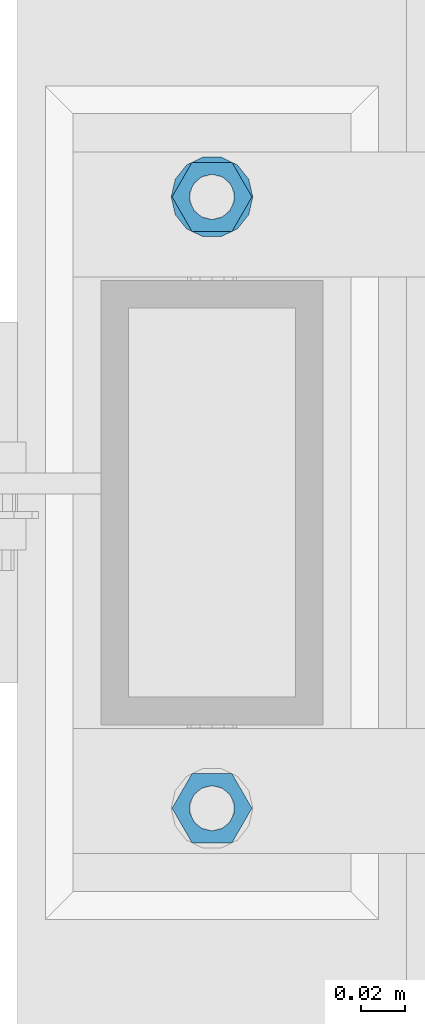
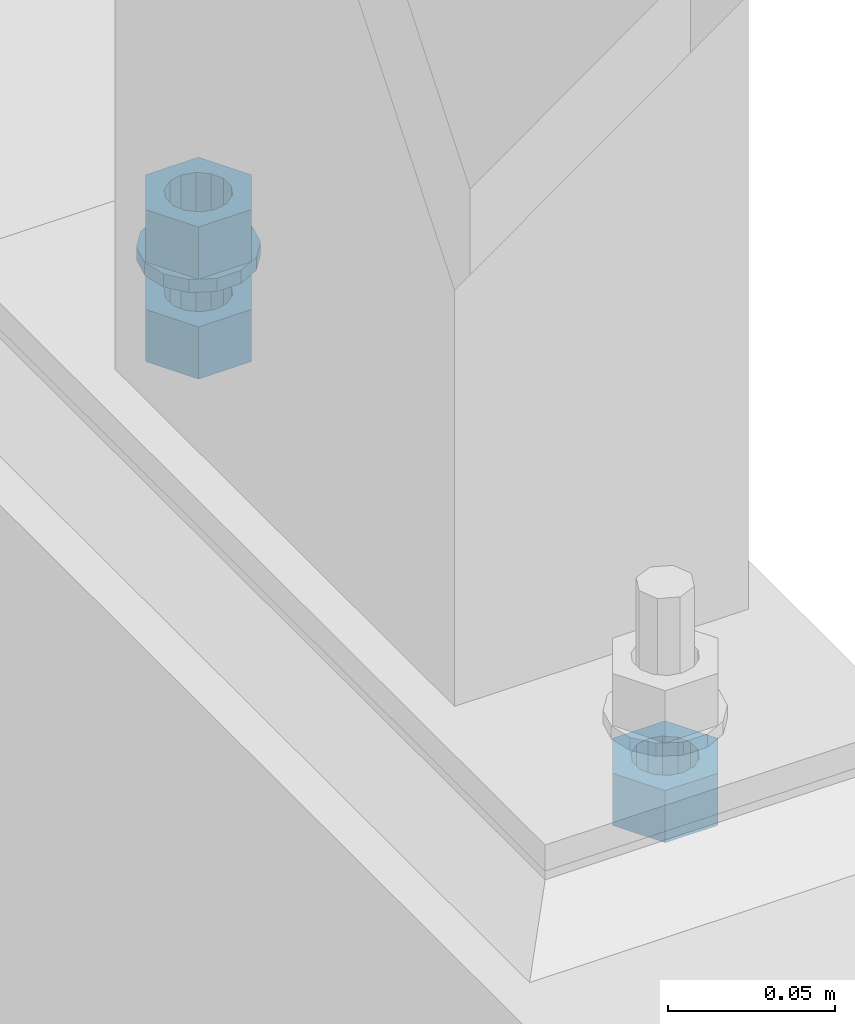
# One storey, part 581 of 975: 4 beams.
"""IFC2X3 building model written with IfcOpenShell, lengths in millimetres."""

from ifc_helpers import new_model, si_unit, frame, origin_with_axes, place, context, subcontext, project, spatial, faceted_brep, material, type_object, element, save


model = new_model("IFC2X3")

# Units and contexts
model_context = context("Model", 3, precision=1e-05, world=origin_with_axes())
body_context = subcontext(model_context, "Body", "Model", "MODEL_VIEW")
ifc_project = project(units=[si_unit("LENGTHUNIT", "METRE", prefix="MILLI"), si_unit("AREAUNIT", "SQUARE_METRE"), si_unit("VOLUMEUNIT", "CUBIC_METRE"), si_unit("MASSUNIT", "GRAM", prefix="KILO"), si_unit("TIMEUNIT", "SECOND"), si_unit("PLANEANGLEUNIT", "RADIAN"), si_unit("SOLIDANGLEUNIT", "STERADIAN"), si_unit("THERMODYNAMICTEMPERATUREUNIT", "DEGREE_CELSIUS"), si_unit("LUMINOUSINTENSITYUNIT", "LUMEN")], contexts=[model_context])

# Site, building, storey
site_placement = place(None, origin_with_axes())
site = spatial("IfcSite", under=ifc_project, at=site_placement, CompositionType="ELEMENT")
building_placement = place(site_placement, origin_with_axes())
building = spatial("IfcBuilding", under=site, at=building_placement, Name="Undefined", CompositionType="ELEMENT")
storey_placement = place(building_placement, origin_with_axes())
storey = spatial("IfcBuildingStorey", under=building, at=storey_placement, Name="Undefined", CompositionType="ELEMENT", Elevation=0.0)

# Beams
ifc_material = material(Name="STEEL/A36")
beam_type_1 = type_object("IfcBeamType", Name="3/4_WASHER", PredefinedType="NOTDEFINED")
beam_1_placement = place(storey_placement, frame((26492.2, 3830.63747558594, 42.8625000000034), z_axis=(0.0, 1.0, 0.0), x_axis=(0.0, 0.0, -1.0)))
element("IfcBeam", 1, at=beam_1_placement, inside=storey, type_object=beam_type_1, material=ifc_material, Name="WASHER", ObjectType="3/4_WASHER", context=body_context, shape_type="Brep", body=[
    faceted_brep([(0.0, -18.6499996185303, 0.0), (0.0, -16.8030690426876, -8.09193156902904), (4.76250000000073, -16.8030690426876, -8.09193156902904), (4.76250000000073, -18.6499996185303, 0.0), (0.0, -11.6280845668225, -14.5811568497838), (4.76250000000073, -11.6280845668225, -14.5811568497838), (0.0, -4.15001533340001, -18.1824051902857), (4.76250000000073, -4.15001533340001, -18.1824051902857), (0.0, 4.15001533340001, -18.1824051902857), (4.76250000000073, 4.15001533340001, -18.1824051902857), (0.0, 11.6280845668234, -14.5811568497838), (4.76250000000073, 11.6280845668234, -14.5811568497838), (0.0, 16.8030690426876, -8.09193156902904), (4.76250000000073, 16.8030690426876, -8.09193156902904), (0.0, 18.6499996185303, 0.0), (4.76250000000073, 18.6499996185303, 0.0), (0.0, 16.8030690426876, 8.09193156902904), (4.76250000000073, 16.8030690426876, 8.09193156902904), (0.0, 11.6280845668225, 14.5811568497838), (4.76250000000073, 11.6280845668225, 14.5811568497838), (0.0, 4.15001533340001, 18.1824051902857), (4.76250000000073, 4.15001533340001, 18.1824051902857), (0.0, -4.15001533340001, 18.1824051902857), (4.76250000000073, -4.15001533340001, 18.1824051902857), (0.0, -11.6280845668234, 14.5811568497838), (4.76250000000073, -11.6280845668234, 14.5811568497838), (0.0, -16.8030690426876, 8.09193156902904), (4.76250000000073, -16.8030690426876, 8.09193156902904), (0.0, 0.0, 10.3199996948242), (0.0, 4.47768005528269, 9.29799844179911), (4.76250000000073, 4.47768005528269, 9.29799844179911), (4.76250000000073, 0.0, 10.3199996948242), (0.0, 8.06850066047446, 6.43441456490817), (4.76250000000073, 8.06850066047446, 6.43441456490817), (0.0, 10.0612557561917, 2.29641597052117), (4.76250000000073, 10.0612557561917, 2.29641597052117), (0.0, 10.0612557561917, -2.29641597052117), (4.76250000000073, 10.0612557561917, -2.29641597052117), (0.0, 8.06850066047446, -6.43441456490814), (4.76250000000073, 8.06850066047446, -6.43441456490814), (0.0, 4.47768005528269, -9.29799844179908), (4.76250000000073, 4.47768005528269, -9.29799844179908), (0.0, 0.0, -10.3199996948242), (4.76250000000073, 0.0, -10.3199996948242), (0.0, -4.47768005528269, -9.29799844179911), (4.76250000000073, -4.47768005528269, -9.29799844179911), (0.0, -8.06850066047446, -6.43441456490817), (4.76250000000073, -8.06850066047446, -6.43441456490817), (0.0, -10.0612557561917, -2.29641597052117), (4.76250000000073, -10.0612557561917, -2.29641597052117), (0.0, -10.0612557561917, 2.29641597052117), (4.76250000000073, -10.0612557561917, 2.29641597052117), (0.0, -8.06850066047446, 6.43441456490814), (4.76250000000073, -8.06850066047446, 6.43441456490814), (0.0, -4.47768005528269, 9.29799844179908), (4.76250000000073, -4.47768005528269, 9.29799844179908)], [[[0, 1, 2, 3]], [[1, 4, 5, 2]], [[4, 6, 7, 5]], [[6, 8, 9, 7]], [[8, 10, 11, 9]], [[10, 12, 13, 11]], [[12, 14, 15, 13]], [[14, 16, 17, 15]], [[16, 18, 19, 17]], [[18, 20, 21, 19]], [[20, 22, 23, 21]], [[22, 24, 25, 23]], [[24, 26, 27, 25]], [[26, 0, 3, 27]], [[28, 29, 30, 31]], [[29, 32, 33, 30]], [[32, 34, 35, 33]], [[34, 36, 37, 35]], [[36, 38, 39, 37]], [[38, 40, 41, 39]], [[40, 42, 43, 41]], [[42, 44, 45, 43]], [[44, 46, 47, 45]], [[46, 48, 49, 47]], [[48, 50, 51, 49]], [[50, 52, 53, 51]], [[52, 54, 55, 53]], [[54, 28, 31, 55]], [[5, 7, 9, 11, 13, 15, 17, 19, 21, 23, 25, 27, 3, 2], [33, 35, 37, 39, 41, 43, 45, 47, 49, 51, 53, 55, 31, 30]], [[26, 24, 22, 20, 18, 16, 14, 12, 10, 8, 6, 4, 1, 0], [54, 52, 50, 48, 46, 44, 42, 40, 38, 36, 34, 32, 29, 28]]]),
])
beam_type_2 = type_object("IfcBeamType", Name="3/4_HEAVY_HEX_NUT", PredefinedType="NOTDEFINED")
beam_2_placement = place(storey_placement, frame((26492.2, 3551.23747558594, 25.4000000000037), z_axis=(0.0, 1.0, 0.0), x_axis=(0.0, 0.0, -1.0)))
element("IfcBeam", 2, at=beam_2_placement, inside=storey, type_object=beam_type_2, material=ifc_material, Name="NUT", ObjectType="3/4_HEAVY_HEX_NUT", context=body_context, shape_type="Brep", body=[
    faceted_brep([(0.0, -18.2600002288818, 0.0), (0.0, -9.13000011444092, -15.8100004196167), (19.0499999999993, -9.13000011444092, -15.8100004196167), (19.0499999999993, -18.2600002288818, 0.0), (0.0, 9.13000011444092, -15.8100004196167), (19.0499999999993, 9.13000011444092, -15.8100004196167), (0.0, 18.2600002288818, 0.0), (19.0499999999993, 18.2600002288818, 0.0), (0.0, 9.13000011444092, 15.8100004196167), (19.0499999999993, 9.13000011444092, 15.8100004196167), (0.0, -9.13000011444092, 15.8100004196167), (19.0499999999993, -9.13000011444092, 15.8100004196167), (0.0, 0.0, 10.3199996948242), (0.0, 4.47768005528269, 9.29799844179911), (19.0499999999993, 4.47768005528269, 9.29799844179911), (19.0499999999993, 0.0, 10.3199996948242), (0.0, 8.06850066047446, 6.43441456490817), (19.0499999999993, 8.06850066047446, 6.43441456490817), (0.0, 10.0612557561917, 2.29641597052117), (19.0499999999993, 10.0612557561917, 2.29641597052117), (0.0, 10.0612557561917, -2.29641597052117), (19.0499999999993, 10.0612557561917, -2.29641597052117), (0.0, 8.06850066047446, -6.43441456490814), (19.0499999999993, 8.06850066047446, -6.43441456490814), (0.0, 4.47768005528269, -9.29799844179908), (19.0499999999993, 4.47768005528269, -9.29799844179908), (0.0, 0.0, -10.3199996948242), (19.0499999999993, 0.0, -10.3199996948242), (0.0, -4.47768005528269, -9.29799844179911), (19.0499999999993, -4.47768005528269, -9.29799844179911), (0.0, -8.06850066047446, -6.43441456490817), (19.0499999999993, -8.06850066047446, -6.43441456490817), (0.0, -10.0612557561917, -2.29641597052117), (19.0499999999993, -10.0612557561917, -2.29641597052117), (0.0, -10.0612557561917, 2.29641597052117), (19.0499999999993, -10.0612557561917, 2.29641597052117), (0.0, -8.06850066047446, 6.43441456490814), (19.0499999999993, -8.06850066047446, 6.43441456490814), (0.0, -4.47768005528269, 9.29799844179908), (19.0499999999993, -4.47768005528269, 9.29799844179908)], [[[0, 1, 2, 3]], [[1, 4, 5, 2]], [[4, 6, 7, 5]], [[6, 8, 9, 7]], [[8, 10, 11, 9]], [[10, 0, 3, 11]], [[12, 13, 14, 15]], [[13, 16, 17, 14]], [[16, 18, 19, 17]], [[18, 20, 21, 19]], [[20, 22, 23, 21]], [[22, 24, 25, 23]], [[24, 26, 27, 25]], [[26, 28, 29, 27]], [[28, 30, 31, 29]], [[30, 32, 33, 31]], [[32, 34, 35, 33]], [[34, 36, 37, 35]], [[36, 38, 39, 37]], [[38, 12, 15, 39]], [[5, 7, 9, 11, 3, 2], [17, 19, 21, 23, 25, 27, 29, 31, 33, 35, 37, 39, 15, 14]], [[10, 8, 6, 4, 1, 0], [38, 36, 34, 32, 30, 28, 26, 24, 22, 20, 18, 16, 13, 12]]]),
])
beam_3_placement = place(storey_placement, frame((26492.2, 3830.63747558594, 61.9125000000026), z_axis=(0.0, 1.0, 0.0), x_axis=(0.0, 0.0, -1.0)))
element("IfcBeam", 3, at=beam_3_placement, inside=storey, type_object=beam_type_2, material=ifc_material, Name="NUT", ObjectType="3/4_HEAVY_HEX_NUT", context=body_context, shape_type="Brep", body=[
    faceted_brep([(0.0, -18.2600002288818, 0.0), (0.0, -9.13000011444092, -15.8100004196167), (19.0499999999993, -9.13000011444092, -15.8100004196167), (19.0499999999993, -18.2600002288818, 0.0), (0.0, 9.13000011444092, -15.8100004196167), (19.0499999999993, 9.13000011444092, -15.8100004196167), (0.0, 18.2600002288818, 0.0), (19.0499999999993, 18.2600002288818, 0.0), (0.0, 9.13000011444092, 15.8100004196167), (19.0499999999993, 9.13000011444092, 15.8100004196167), (0.0, -9.13000011444092, 15.8100004196167), (19.0499999999993, -9.13000011444092, 15.8100004196167), (0.0, 0.0, 10.3199996948242), (0.0, 4.47768005528269, 9.29799844179911), (19.0499999999993, 4.47768005528269, 9.29799844179911), (19.0499999999993, 0.0, 10.3199996948242), (0.0, 8.06850066047446, 6.43441456490817), (19.0499999999993, 8.06850066047446, 6.43441456490817), (0.0, 10.0612557561917, 2.29641597052117), (19.0499999999993, 10.0612557561917, 2.29641597052117), (0.0, 10.0612557561917, -2.29641597052117), (19.0499999999993, 10.0612557561917, -2.29641597052117), (0.0, 8.06850066047446, -6.43441456490814), (19.0499999999993, 8.06850066047446, -6.43441456490814), (0.0, 4.47768005528269, -9.29799844179908), (19.0499999999993, 4.47768005528269, -9.29799844179908), (0.0, 0.0, -10.3199996948242), (19.0499999999993, 0.0, -10.3199996948242), (0.0, -4.47768005528269, -9.29799844179911), (19.0499999999993, -4.47768005528269, -9.29799844179911), (0.0, -8.06850066047446, -6.43441456490817), (19.0499999999993, -8.06850066047446, -6.43441456490817), (0.0, -10.0612557561917, -2.29641597052117), (19.0499999999993, -10.0612557561917, -2.29641597052117), (0.0, -10.0612557561917, 2.29641597052117), (19.0499999999993, -10.0612557561917, 2.29641597052117), (0.0, -8.06850066047446, 6.43441456490814), (19.0499999999993, -8.06850066047446, 6.43441456490814), (0.0, -4.47768005528269, 9.29799844179908), (19.0499999999993, -4.47768005528269, 9.29799844179908)], [[[0, 1, 2, 3]], [[1, 4, 5, 2]], [[4, 6, 7, 5]], [[6, 8, 9, 7]], [[8, 10, 11, 9]], [[10, 0, 3, 11]], [[12, 13, 14, 15]], [[13, 16, 17, 14]], [[16, 18, 19, 17]], [[18, 20, 21, 19]], [[20, 22, 23, 21]], [[22, 24, 25, 23]], [[24, 26, 27, 25]], [[26, 28, 29, 27]], [[28, 30, 31, 29]], [[30, 32, 33, 31]], [[32, 34, 35, 33]], [[34, 36, 37, 35]], [[36, 38, 39, 37]], [[38, 12, 15, 39]], [[5, 7, 9, 11, 3, 2], [17, 19, 21, 23, 25, 27, 29, 31, 33, 35, 37, 39, 15, 14]], [[10, 8, 6, 4, 1, 0], [38, 36, 34, 32, 30, 28, 26, 24, 22, 20, 18, 16, 13, 12]]]),
])
beam_4_placement = place(storey_placement, frame((26492.2, 3830.63747558594, 25.4000000000037), z_axis=(0.0, 1.0, 0.0), x_axis=(0.0, 0.0, -1.0)))
element("IfcBeam", 4, at=beam_4_placement, inside=storey, type_object=beam_type_2, material=ifc_material, Name="NUT", ObjectType="3/4_HEAVY_HEX_NUT", context=body_context, shape_type="Brep", body=[
    faceted_brep([(0.0, -18.2600002288818, 0.0), (0.0, -9.13000011444092, -15.8100004196167), (19.0499999999993, -9.13000011444092, -15.8100004196167), (19.0499999999993, -18.2600002288818, 0.0), (0.0, 9.13000011444092, -15.8100004196167), (19.0499999999993, 9.13000011444092, -15.8100004196167), (0.0, 18.2600002288818, 0.0), (19.0499999999993, 18.2600002288818, 0.0), (0.0, 9.13000011444092, 15.8100004196167), (19.0499999999993, 9.13000011444092, 15.8100004196167), (0.0, -9.13000011444092, 15.8100004196167), (19.0499999999993, -9.13000011444092, 15.8100004196167), (0.0, 0.0, 10.3199996948242), (0.0, 4.47768005528269, 9.29799844179911), (19.0499999999993, 4.47768005528269, 9.29799844179911), (19.0499999999993, 0.0, 10.3199996948242), (0.0, 8.06850066047446, 6.43441456490817), (19.0499999999993, 8.06850066047446, 6.43441456490817), (0.0, 10.0612557561917, 2.29641597052117), (19.0499999999993, 10.0612557561917, 2.29641597052117), (0.0, 10.0612557561917, -2.29641597052117), (19.0499999999993, 10.0612557561917, -2.29641597052117), (0.0, 8.06850066047446, -6.43441456490814), (19.0499999999993, 8.06850066047446, -6.43441456490814), (0.0, 4.47768005528269, -9.29799844179908), (19.0499999999993, 4.47768005528269, -9.29799844179908), (0.0, 0.0, -10.3199996948242), (19.0499999999993, 0.0, -10.3199996948242), (0.0, -4.47768005528269, -9.29799844179911), (19.0499999999993, -4.47768005528269, -9.29799844179911), (0.0, -8.06850066047446, -6.43441456490817), (19.0499999999993, -8.06850066047446, -6.43441456490817), (0.0, -10.0612557561917, -2.29641597052117), (19.0499999999993, -10.0612557561917, -2.29641597052117), (0.0, -10.0612557561917, 2.29641597052117), (19.0499999999993, -10.0612557561917, 2.29641597052117), (0.0, -8.06850066047446, 6.43441456490814), (19.0499999999993, -8.06850066047446, 6.43441456490814), (0.0, -4.47768005528269, 9.29799844179908), (19.0499999999993, -4.47768005528269, 9.29799844179908)], [[[0, 1, 2, 3]], [[1, 4, 5, 2]], [[4, 6, 7, 5]], [[6, 8, 9, 7]], [[8, 10, 11, 9]], [[10, 0, 3, 11]], [[12, 13, 14, 15]], [[13, 16, 17, 14]], [[16, 18, 19, 17]], [[18, 20, 21, 19]], [[20, 22, 23, 21]], [[22, 24, 25, 23]], [[24, 26, 27, 25]], [[26, 28, 29, 27]], [[28, 30, 31, 29]], [[30, 32, 33, 31]], [[32, 34, 35, 33]], [[34, 36, 37, 35]], [[36, 38, 39, 37]], [[38, 12, 15, 39]], [[5, 7, 9, 11, 3, 2], [17, 19, 21, 23, 25, 27, 29, 31, 33, 35, 37, 39, 15, 14]], [[10, 8, 6, 4, 1, 0], [38, 36, 34, 32, 30, 28, 26, 24, 22, 20, 18, 16, 13, 12]]]),
])

save(model, "model.ifc")
